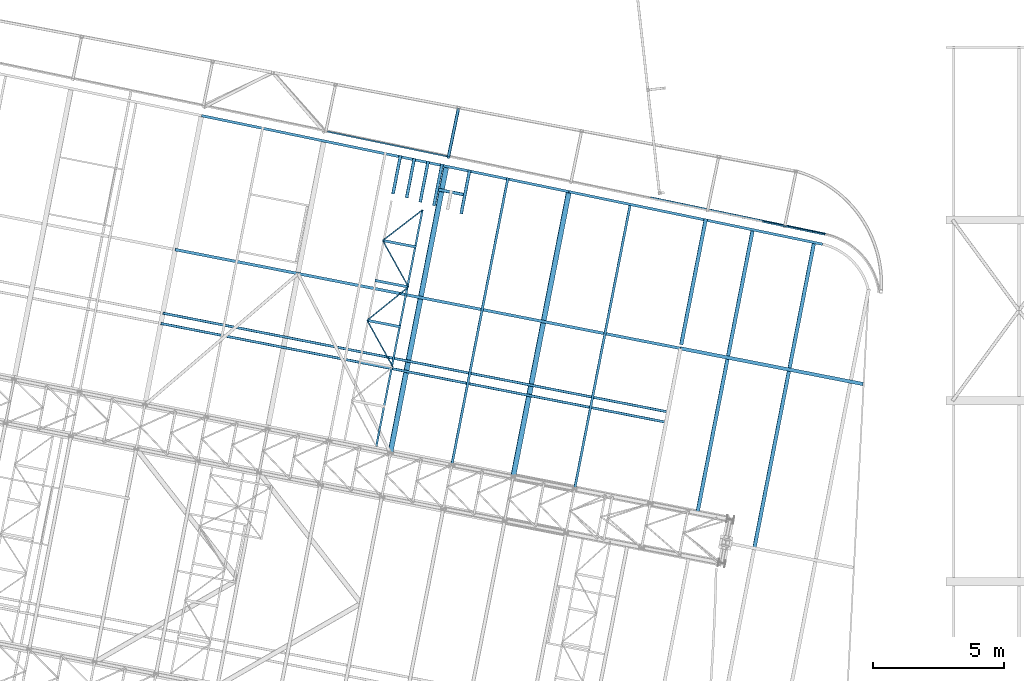
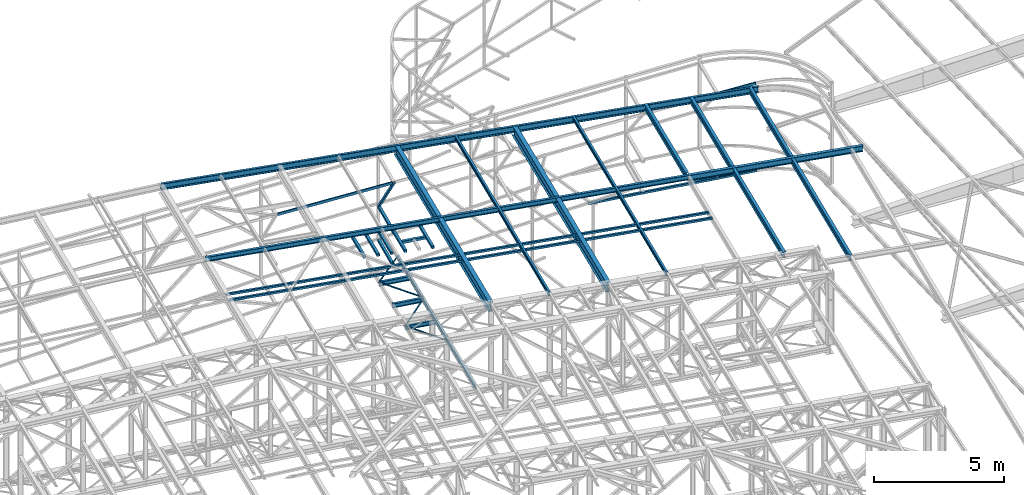
# One storey, part 99 of 215: 32 beams, 1 member, 33 elements without a shape of their own.
"""IFC2X3 building model written with IfcOpenShell, lengths in millimetres."""

from ifc_helpers import new_model, si_unit, frame, origin_with_axes, origin_2d_with_axis, place, context, subcontext, project, spatial, hollow_rectangle, i_section, u_section, extrude, clip, halfspace, material, type_object, element, aggregate, save


model = new_model("IFC2X3")

# Units and contexts
model_context = context("Model", 3, precision=1e-05, world=origin_with_axes())
body_context = subcontext(model_context, "Body", "Model", "MODEL_VIEW")
ifc_project = project(units=[si_unit("LENGTHUNIT", "METRE", prefix="MILLI"), si_unit("AREAUNIT", "SQUARE_METRE"), si_unit("VOLUMEUNIT", "CUBIC_METRE"), si_unit("MASSUNIT", "GRAM", prefix="KILO"), si_unit("TIMEUNIT", "SECOND"), si_unit("PLANEANGLEUNIT", "RADIAN"), si_unit("SOLIDANGLEUNIT", "STERADIAN"), si_unit("THERMODYNAMICTEMPERATUREUNIT", "DEGREE_CELSIUS"), si_unit("LUMINOUSINTENSITYUNIT", "LUMEN")], contexts=[model_context])

# Site, building, storey
site_placement = place(None, origin_with_axes())
site = spatial("IfcSite", under=ifc_project, at=site_placement, CompositionType="ELEMENT")
building_placement = place(site_placement, origin_with_axes())
building = spatial("IfcBuilding", under=site, at=building_placement, Name="Undefined", CompositionType="ELEMENT")
storey_placement = place(building_placement, origin_with_axes())
storey = spatial("IfcBuildingStorey", under=building, at=storey_placement, Name="Undefined", CompositionType="ELEMENT", Elevation=0.0)

# Assembly, beam
assembly_1_placement = place(storey_placement, origin_with_axes())
assembly_1 = element("IfcElementAssembly", 1, at=assembly_1_placement, inside=storey, Name="Steel Assembly", AssemblyPlace="NOTDEFINED", PredefinedType="RIGID_FRAME")
ifc_material = material(Name="STEEL/S275JR")
beam_type_1 = type_object("IfcBeamType", Name="IPE270", PredefinedType="NOTDEFINED")
beam_1_placement = place(assembly_1_placement, frame((100707.23121644, 49411.6988789502, 11955.4438680864), z_axis=(0.0304080349965938, -0.00594450399933318, 0.999519891888024), x_axis=(-0.980951221876683, 0.191767344975893, 0.0309836359961049)))
beam_1 = element("IfcBeam", 2, at=beam_1_placement, type_object=beam_type_1, material=ifc_material, Name="TRAVERSE", ObjectType="IPE270", context=body_context, shape_type="SweptSolid", body=[
    extrude(i_section(OverallWidth=135.0, OverallDepth=270.0, WebThickness=6.599999905, FlangeThickness=10.19999981, FilletRadius=15.0, at=origin_2d_with_axis()), frame((7103.1034453128, -3.20526009538818e-13, 0.0), z_axis=(-1.0, 0.0, 0.0), x_axis=(-6.93889390390723e-18, -1.0, -3.46944695195361e-18)), (0.0, 0.0, 1.0), 7103.1),
])
aggregate(assembly_1, [beam_1])

assembly_2_placement = place(storey_placement, origin_with_axes())
assembly_2 = element("IfcElementAssembly", 3, at=assembly_2_placement, inside=storey, Name="Steel Assembly", AssemblyPlace="NOTDEFINED", PredefinedType="RIGID_FRAME")
beam_2_placement = place(assembly_2_placement, frame((94696.1400825468, 55667.7027853643, 12176.4184972957), z_axis=(-0.0304080339975108, 0.00594450399951394, -0.999519891918418), x_axis=(-0.191859508000518, -0.981422401002646, -1.00000033853845e-09)))
beam_2 = element("IfcBeam", 4, at=beam_2_placement, type_object=beam_type_1, material=ifc_material, ObjectType="IPE270", context=body_context, shape_type="Clipping", body=[
    clip(extrude(i_section(OverallWidth=135.0, OverallDepth=270.0, WebThickness=6.599999905, FlangeThickness=10.19999981, FilletRadius=15.0, at=origin_2d_with_axis()), frame((4844.78748457734, -1.445755833281e-11, 1.82295988638934e-12), z_axis=(-1.0, 0.0, 0.0), x_axis=(-6.93889390390723e-18, -1.0, -3.46944695195361e-18)), (0.0, 0.0, 1.0), 4957.0), halfspace(frame((-57.8522149335477, -299.270143802947, 12172.9903718911), z_axis=(0.999938312877608, 0.0111018920303277, 0.000344140712308602), x_axis=(-1.55650195665657e-09, 0.0309836416144971, -0.999519891724174)), True)),
])
aggregate(assembly_2, [beam_2])

assembly_3_placement = place(storey_placement, origin_with_axes())
assembly_3 = element("IfcElementAssembly", 5, at=assembly_3_placement, inside=storey, Name="Steel Assembly", AssemblyPlace="NOTDEFINED", PredefinedType="RIGID_FRAME")
beam_3_placement = place(assembly_3_placement, frame((96557.6967211372, 43142.8449934824, 12044.4005914881), z_axis=(0.0304080349965938, -0.00594450399933318, 0.999519891888024), x_axis=(0.191863232960539, 0.981421672798148, -1.19000000001358e-07)))
beam_3 = element("IfcBeam", 6, at=beam_3_placement, type_object=beam_type_1, material=ifc_material, ObjectType="IPE270", context=body_context, shape_type="Clipping", body=[
    clip(extrude(i_section(OverallWidth=135.0, OverallDepth=270.0, WebThickness=6.599999905, FlangeThickness=10.19999981, FilletRadius=15.0, at=origin_2d_with_axis()), frame((12000.275121303, 3.47876669497256e-13, -8.68726319428626e-15), z_axis=(-1.0, 0.0, 0.0), x_axis=(-6.93889390390723e-18, -1.0, -3.46944695195361e-18)), (0.0, 0.0, 1.0), 12000.3), halfspace(frame((11948.0422010273, -101.391752407799, -12047.0416624996), z_axis=(0.999938514081791, -0.0110837688422926, 0.000343691942567653), x_axis=(-1.11477173049934e-07, 0.0309836363285431, 0.999519891888024)), False)),
])
aggregate(assembly_3, [beam_3])

assembly_4_placement = place(storey_placement, origin_with_axes())
assembly_4 = element("IfcElementAssembly", 7, at=assembly_4_placement, inside=storey, Name="Steel Assembly", AssemblyPlace="NOTDEFINED", PredefinedType="RIGID_FRAME")
beam_4_placement = place(assembly_4_placement, frame((94384.2962147802, 44489.533243236, 12118.5356235936), z_axis=(0.0304080349965938, -0.00594450399933318, 0.999519891888024), x_axis=(0.191845211931802, 0.981425195651121, 9.9999994476379e-10)))
beam_4 = element("IfcBeam", 8, at=beam_4_placement, type_object=beam_type_1, material=ifc_material, ObjectType="IPE270", context=body_context, shape_type="Clipping", body=[
    clip(extrude(i_section(OverallWidth=135.0, OverallDepth=270.0, WebThickness=6.599999905, FlangeThickness=10.19999981, FilletRadius=15.0, at=origin_2d_with_axis()), frame((11122.1477016745, -1.45519152283669e-11, 0.0), z_axis=(-1.0, 0.0, 0.0), x_axis=(-6.93889390390723e-18, -1.0, -3.46944695195361e-18)), (0.0, 0.0, 1.0), 11122.1), halfspace(frame((11069.8103499635, -114.010455299445, -12120.8224702647), z_axis=(-0.999938146591681, 0.0111168447564954, -0.000344606230971227), x_axis=(-1.11477173049934e-07, 0.0309836363285431, 0.999519891888024)), True)),
])
aggregate(assembly_4, [beam_4])

assembly_5_placement = place(storey_placement, origin_with_axes())
assembly_5 = element("IfcElementAssembly", 9, at=assembly_5_placement, inside=storey, Name="Steel Assembly", AssemblyPlace="NOTDEFINED", PredefinedType="RIGID_FRAME")
beam_type_2 = type_object("IfcBeamType", PredefinedType="NOTDEFINED")
beam_5_placement = place(assembly_5_placement, frame((84507.3845656861, 56831.7887650236, 8709.9999999772), z_axis=(0.0, 0.0, -1.0), x_axis=(0.981422136483614, -0.191860861094538, 0.0)))
beam_5 = element("IfcBeam", 10, at=beam_5_placement, type_object=beam_type_2, material=ifc_material, context=body_context, shape_type="SweptSolid", body=[
    extrude(hollow_rectangle(XDim=120.0, YDim=120.0, WallThickness=5.0, InnerFilletRadius=5.0, OuterFilletRadius=10.0, at=origin_2d_with_axis()), frame((960.000000021923, -2.66453525916122e-14, 0.0), z_axis=(-1.0, 0.0, 0.0), x_axis=(-6.93889390390723e-18, -1.0, -3.46944695195361e-18)), (0.0, 0.0, 1.0), 960.0),
])
aggregate(assembly_5, [beam_5])

assembly_6_placement = place(storey_placement, origin_with_axes())
assembly_6 = element("IfcElementAssembly", 11, at=assembly_6_placement, inside=storey, Name="Steel Assembly", AssemblyPlace="NOTDEFINED", PredefinedType="RIGID_FRAME")
beam_6_placement = place(assembly_6_placement, frame((84326.0255883103, 56216.8133377189, 8710.00000001529), z_axis=(0.0, 0.0, -1.0), x_axis=(0.191860861094545, 0.981422136483613, 0.0)))
beam_6 = element("IfcBeam", 12, at=beam_6_placement, type_object=beam_type_2, material=ifc_material, context=body_context, shape_type="SweptSolid", body=[
    extrude(hollow_rectangle(XDim=120.0, YDim=120.0, WallThickness=5.0, InnerFilletRadius=5.0, OuterFilletRadius=10.0, at=origin_2d_with_axis()), frame((1625.85446433249, 0.0, 0.0), z_axis=(-1.0, 0.0, 0.0), x_axis=(-6.93889390390723e-18, -1.0, -3.46944695195361e-18)), (0.0, 0.0, 1.0), 1625.9),
])
aggregate(assembly_6, [beam_6])

assembly_7_placement = place(storey_placement, origin_with_axes())
assembly_7 = element("IfcElementAssembly", 13, at=assembly_7_placement, inside=storey, Name="Steel Assembly", AssemblyPlace="NOTDEFINED", PredefinedType="RIGID_FRAME")
beam_7_placement = place(assembly_7_placement, frame((83802.4829464873, 56353.2854755301, 8710.00000001752), z_axis=(0.0, 0.0, -1.0), x_axis=(0.191860861094545, 0.981422136483613, 0.0)))
beam_7 = element("IfcBeam", 14, at=beam_7_placement, type_object=beam_type_2, material=ifc_material, context=body_context, shape_type="SweptSolid", body=[
    extrude(hollow_rectangle(XDim=120.0, YDim=120.0, WallThickness=5.0, InnerFilletRadius=5.0, OuterFilletRadius=10.0, at=origin_2d_with_axis()), frame((1592.36502932667, -4.41970079791596e-14, 0.0), z_axis=(-1.0, 0.0, 0.0), x_axis=(-6.93889390390723e-18, -1.0, -3.46944695195361e-18)), (0.0, 0.0, 1.0), 1592.4),
])
aggregate(assembly_7, [beam_7])

assembly_8_placement = place(storey_placement, origin_with_axes())
assembly_8 = element("IfcElementAssembly", 15, at=assembly_8_placement, inside=storey, Name="Steel Assembly", AssemblyPlace="NOTDEFINED", PredefinedType="RIGID_FRAME")
beam_8_placement = place(assembly_8_placement, frame((83284.5034089616, 56518.2144525456, 8710.00000001459), z_axis=(0.0, 0.0, -1.0), x_axis=(0.191860861094545, 0.981422136483613, 0.0)))
beam_8 = element("IfcBeam", 16, at=beam_8_placement, type_object=beam_type_2, material=ifc_material, context=body_context, shape_type="SweptSolid", body=[
    extrude(hollow_rectangle(XDim=120.0, YDim=120.0, WallThickness=5.0, InnerFilletRadius=5.0, OuterFilletRadius=10.0, at=origin_2d_with_axis()), frame((1529.88008044036, 0.0, -1.81898940354586e-12), z_axis=(-1.0, 0.0, 0.0), x_axis=(-6.93889390390723e-18, -1.0, -3.46944695195361e-18)), (0.0, 0.0, 1.0), 1529.9),
])
aggregate(assembly_8, [beam_8])

assembly_9_placement = place(storey_placement, origin_with_axes())
assembly_9 = element("IfcElementAssembly", 17, at=assembly_9_placement, inside=storey, Name="Steel Assembly", AssemblyPlace="NOTDEFINED", PredefinedType="RIGID_FRAME")
beam_9_placement = place(assembly_9_placement, frame((85366.045242537, 55907.7263847116, 8710.00000000988), z_axis=(0.0, 0.0, -1.0), x_axis=(0.191860861094545, 0.981422136483613, 0.0)))
beam_9 = element("IfcBeam", 18, at=beam_9_placement, type_object=beam_type_2, material=ifc_material, context=body_context, shape_type="SweptSolid", body=[
    extrude(hollow_rectangle(XDim=120.0, YDim=120.0, WallThickness=5.0, InnerFilletRadius=5.0, OuterFilletRadius=10.0, at=origin_2d_with_axis()), frame((1712.99697636655, 4.75452171068856e-14, 0.0), z_axis=(-1.0, 0.0, 0.0), x_axis=(-6.93889390390723e-18, -1.0, -3.46944695195361e-18)), (0.0, 0.0, 1.0), 1713.0),
])
aggregate(assembly_9, [beam_9])

assembly_10_placement = place(storey_placement, origin_with_axes())
assembly_10 = element("IfcElementAssembly", 19, at=assembly_10_placement, inside=storey, Name="Steel Assembly", AssemblyPlace="NOTDEFINED", PredefinedType="RIGID_FRAME")
beam_10_placement = place(assembly_10_placement, frame((82763.4577222921, 56667.4592165135, 8710.00000000836), z_axis=(0.0, 0.0, -1.0), x_axis=(0.191860861094545, 0.981422136483613, 0.0)))
beam_10 = element("IfcBeam", 20, at=beam_10_placement, type_object=beam_type_2, material=ifc_material, context=body_context, shape_type="SweptSolid", body=[
    extrude(hollow_rectangle(XDim=120.0, YDim=120.0, WallThickness=5.0, InnerFilletRadius=5.0, OuterFilletRadius=10.0, at=origin_2d_with_axis()), frame((1497.35905620603, 0.0, 0.0), z_axis=(-1.0, 0.0, 0.0), x_axis=(-6.93889390390723e-18, -1.0, -3.46944695195361e-18)), (0.0, 0.0, 1.0), 1497.4),
])
aggregate(assembly_10, [beam_10])

assembly_11_placement = place(storey_placement, origin_with_axes())
assembly_11 = element("IfcElementAssembly", 21, at=assembly_11_placement, inside=storey, Name="Steel Assembly", AssemblyPlace="NOTDEFINED", PredefinedType="RIGID_FRAME")
beam_11_placement = place(assembly_11_placement, frame((85256.4215637846, 59899.7622415471, 6680.22396478486), z_axis=(0.979315017537065, -0.202341534110965, 0.0), x_axis=(-0.202341520089688, -0.979315020434076, -1.000000338979e-09)))
beam_11 = element("IfcBeam", 22, at=beam_11_placement, type_object=beam_type_2, material=ifc_material, context=body_context, shape_type="SweptSolid", body=[
    extrude(hollow_rectangle(XDim=120.0, YDim=120.0, WallThickness=5.0, InnerFilletRadius=5.0, OuterFilletRadius=10.0, at=origin_2d_with_axis()), frame((1873.33697915903, 0.0, -5.19955461786024e-14), z_axis=(-1.0, 0.0, 0.0), x_axis=(-6.93889390390723e-18, -1.0, -3.46944695195361e-18)), (0.0, 0.0, 1.0), 1873.3),
])
aggregate(assembly_11, [beam_11])

assembly_12_placement = place(storey_placement, origin_with_axes())
assembly_12 = element("IfcElementAssembly", 23, at=assembly_12_placement, inside=storey, Name="Steel Assembly", AssemblyPlace="NOTDEFINED", PredefinedType="RIGID_FRAME")
beam_12_placement = place(assembly_12_placement, frame((85256.4215637935, 59899.7622415429, 8267.55297995395), z_axis=(0.979315017537065, -0.202341534110965, 0.0), x_axis=(-0.202341520089688, -0.979315020434076, -1.000000338979e-09)))
beam_12 = element("IfcBeam", 24, at=beam_12_placement, type_object=beam_type_2, material=ifc_material, context=body_context, shape_type="SweptSolid", body=[
    extrude(hollow_rectangle(XDim=120.0, YDim=120.0, WallThickness=5.0, InnerFilletRadius=5.0, OuterFilletRadius=10.0, at=origin_2d_with_axis()), frame((1873.33697915903, 0.0, -5.19955461786024e-14), z_axis=(-1.0, 0.0, 0.0), x_axis=(-6.93889390390723e-18, -1.0, -3.46944695195361e-18)), (0.0, 0.0, 1.0), 1873.3),
])
aggregate(assembly_12, [beam_12])

assembly_13_placement = place(storey_placement, origin_with_axes())
assembly_13 = element("IfcElementAssembly", 25, at=assembly_13_placement, inside=storey, Name="Steel Assembly", AssemblyPlace="NOTDEFINED", PredefinedType="RIGID_FRAME")
beam_type_3 = type_object("IfcBeamType", PredefinedType="NOTDEFINED")
beam_13_placement = place(assembly_13_placement, frame((92596.8966885461, 56519.4992647334, 7879.61551005311), z_axis=(0.203415415993803, 0.979092522970154, -7.99999997955808e-08), x_axis=(0.979060179671381, -0.203408695931727, 0.00812816099727176)))
beam_13 = element("IfcBeam", 26, at=beam_13_placement, type_object=beam_type_3, material=ifc_material, Name="LISSE", context=body_context, shape_type="SweptSolid", body=[
    extrude(hollow_rectangle(XDim=100.0, YDim=100.0, WallThickness=5.0, InnerFilletRadius=5.0, OuterFilletRadius=10.0, at=origin_2d_with_axis()), frame((6834.47893677168, 0.0, -1.42196319762222e-11), z_axis=(-1.0, 0.0, 0.0), x_axis=(-6.93889390390723e-18, -1.0, -3.46944695195361e-18)), (0.0, 0.0, 1.0), 6834.5),
])
aggregate(assembly_13, [beam_13])

assembly_14_placement = place(storey_placement, origin_with_axes())
assembly_14 = element("IfcElementAssembly", 27, at=assembly_14_placement, inside=storey, Name="Steel Assembly", AssemblyPlace="NOTDEFINED", PredefinedType="RIGID_FRAME")
beam_14_placement = place(assembly_14_placement, frame((73979.038016216, 52117.5203848683, 12789.6972982422), z_axis=(-0.0304080339975108, 0.00594450399951394, -0.999519891918418), x_axis=(0.980943076639626, -0.191809005929534, -0.0309836349886174)))
beam_14 = element("IfcBeam", 28, at=beam_14_placement, type_object=beam_type_3, material=ifc_material, context=body_context, shape_type="SweptSolid", body=[
    extrude(hollow_rectangle(XDim=100.0, YDim=100.0, WallThickness=5.0, InnerFilletRadius=5.0, OuterFilletRadius=10.0, at=origin_2d_with_axis()), frame((19666.2260350888, 7.85512124139754e-13, 1.81898940354586e-12), z_axis=(-1.0, 0.0, 0.0), x_axis=(-6.93889390390723e-18, -1.0, -3.46944695195361e-18)), (0.0, 0.0, 1.0), 19666.2),
])
aggregate(assembly_14, [beam_14])

assembly_15_placement = place(storey_placement, origin_with_axes())
assembly_15 = element("IfcElementAssembly", 29, at=assembly_15_placement, inside=storey, Name="Steel Assembly", AssemblyPlace="NOTDEFINED", PredefinedType="RIGID_FRAME")
beam_15_placement = place(assembly_15_placement, frame((73901.7838214901, 51725.051223685, 12789.6972993589), z_axis=(-0.0304080339975108, 0.00594450399951394, -0.999519891918418), x_axis=(0.980943076639626, -0.191809005929534, -0.0309836349886174)))
beam_15 = element("IfcBeam", 30, at=beam_15_placement, type_object=beam_type_3, material=ifc_material, context=body_context, shape_type="SweptSolid", body=[
    extrude(hollow_rectangle(XDim=100.0, YDim=100.0, WallThickness=5.0, InnerFilletRadius=5.0, OuterFilletRadius=10.0, at=origin_2d_with_axis()), frame((19666.7288325615, 1.47390537647347e-11, -6.82326724030288e-14), z_axis=(-1.0, 0.0, 0.0), x_axis=(-6.93889390390723e-18, -1.0, -3.46944695195361e-18)), (0.0, 0.0, 1.0), 19666.7),
])
aggregate(assembly_15, [beam_15])

assembly_16_placement = place(storey_placement, origin_with_axes())
assembly_16 = element("IfcElementAssembly", 31, at=assembly_16_placement, inside=storey, Name="Steel Assembly", AssemblyPlace="NOTDEFINED", PredefinedType="RIGID_FRAME")
beam_type_4 = type_object("IfcBeamType", PredefinedType="NOTDEFINED")
beam_16_placement = place(assembly_16_placement, frame((81777.8800450432, 51843.5573353207, 8745.0), z_axis=(0.0, 0.0, -1.0), x_axis=(0.483553584905505, -0.875314760828946, 0.0)))
beam_16 = element("IfcBeam", 32, at=beam_16_placement, type_object=beam_type_4, material=ifc_material, context=body_context, shape_type="SweptSolid", body=[
    extrude(hollow_rectangle(XDim=50.0, YDim=50.0, WallThickness=3.0, InnerFilletRadius=3.0, OuterFilletRadius=6.0, at=origin_2d_with_axis()), frame((2026.56728111941, 0.0, 0.0), z_axis=(-1.0, 0.0, 0.0), x_axis=(-6.93889390390723e-18, -1.0, -3.46944695195361e-18)), (0.0, 0.0, 1.0), 2026.6),
])
aggregate(assembly_16, [beam_16])

assembly_17_placement = place(storey_placement, origin_with_axes())
assembly_17 = element("IfcElementAssembly", 33, at=assembly_17_placement, inside=storey, Name="Steel Assembly", AssemblyPlace="NOTDEFINED", PredefinedType="RIGID_FRAME")
beam_17_placement = place(assembly_17_placement, frame((83353.7207232952, 53117.8024188517, 8745.0), z_axis=(0.0, 0.0, -1.0), x_axis=(-0.777591169660664, -0.628770206725606, 0.0)))
beam_17 = element("IfcBeam", 34, at=beam_17_placement, type_object=beam_type_4, material=ifc_material, context=body_context, shape_type="SweptSolid", body=[
    extrude(hollow_rectangle(XDim=50.0, YDim=50.0, WallThickness=3.0, InnerFilletRadius=3.0, OuterFilletRadius=6.0, at=origin_2d_with_axis()), frame((2026.56718786147, 2.24994155291366e-13, 0.0), z_axis=(-1.0, 0.0, 0.0), x_axis=(-6.93889390390723e-18, -1.0, -3.46944695195361e-18)), (0.0, 0.0, 1.0), 2026.6),
])
aggregate(assembly_17, [beam_17])

assembly_18_placement = place(storey_placement, origin_with_axes())
assembly_18 = element("IfcElementAssembly", 35, at=assembly_18_placement, inside=storey, Name="Steel Assembly", AssemblyPlace="NOTDEFINED", PredefinedType="RIGID_FRAME")
beam_18_placement = place(assembly_18_placement, frame((82373.7669208555, 54891.6866599469, 8745.0), z_axis=(0.0, 0.0, -1.0), x_axis=(0.483553584905505, -0.875314760828946, 0.0)))
beam_18 = element("IfcBeam", 36, at=beam_18_placement, type_object=beam_type_4, material=ifc_material, context=body_context, shape_type="SweptSolid", body=[
    extrude(hollow_rectangle(XDim=50.0, YDim=50.0, WallThickness=3.0, InnerFilletRadius=3.0, OuterFilletRadius=6.0, at=origin_2d_with_axis()), frame((2026.56718786147, 2.24994155291366e-13, 0.0), z_axis=(-1.0, 0.0, 0.0), x_axis=(-6.93889390390723e-18, -1.0, -3.46944695195361e-18)), (0.0, 0.0, 1.0), 2026.6),
])
aggregate(assembly_18, [beam_18])

assembly_19_placement = place(storey_placement, origin_with_axes())
assembly_19 = element("IfcElementAssembly", 37, at=assembly_19_placement, inside=storey, Name="Steel Assembly", AssemblyPlace="NOTDEFINED", PredefinedType="RIGID_FRAME")
beam_19_placement = place(assembly_19_placement, frame((83890.4643411294, 56058.8507650693, 8744.99999998962), z_axis=(0.0, 0.0, -1.0), x_axis=(-0.792504335295169, -0.609866279227146, 0.0)))
beam_19 = element("IfcBeam", 38, at=beam_19_placement, type_object=beam_type_4, material=ifc_material, context=body_context, shape_type="SweptSolid", body=[
    extrude(hollow_rectangle(XDim=50.0, YDim=50.0, WallThickness=3.0, InnerFilletRadius=3.0, OuterFilletRadius=6.0, at=origin_2d_with_axis()), frame((1913.80331128976, 0.0, 1.81898940354586e-12), z_axis=(-1.0, 0.0, 0.0), x_axis=(-6.93889390390723e-18, -1.0, -3.46944695195361e-18)), (0.0, 0.0, 1.0), 1913.8),
])
aggregate(assembly_19, [beam_19])

assembly_20_placement = place(storey_placement, origin_with_axes())
assembly_20 = element("IfcElementAssembly", 39, at=assembly_20_placement, inside=storey, Name="Steel Assembly", AssemblyPlace="NOTDEFINED", PredefinedType="RIGID_FRAME")
beam_type_5 = type_object("IfcBeamType", Name="IPE180", PredefinedType="NOTDEFINED")
beam_20_placement = place(assembly_20_placement, frame((89697.5688418954, 45405.7473703223, 12311.5889128037), z_axis=(0.0304080349965938, -0.00594450399933318, 0.999519891888024), x_axis=(0.191845211931802, 0.981425195651121, 9.9999994476379e-10)))
beam_20 = element("IfcBeam", 40, at=beam_20_placement, type_object=beam_type_5, material=ifc_material, ObjectType="IPE180", context=body_context, shape_type="Clipping", body=[
    clip(extrude(i_section(OverallWidth=91.0, OverallDepth=180.0, WebThickness=5.300000191, FlangeThickness=8.0, FilletRadius=9.0, at=origin_2d_with_axis()), frame((11157.1587552887, -1.45519152283669e-11, 9.67729260899973e-15), z_axis=(-1.0, 0.0, 0.0), x_axis=(-6.93889390390723e-18, -1.0, -3.46944695195361e-18)), (0.0, 0.0, 1.0), 11157.2), halfspace(frame((11120.8339455716, -301.644985928389, -12308.1520979139), z_axis=(-0.999936956705406, 0.0112232605275007, -0.000347904962252072), x_axis=(-1.11477173049934e-07, 0.0309836363285431, 0.999519891888024)), True)),
])
aggregate(assembly_20, [beam_20])

assembly_21_placement = place(storey_placement, origin_with_axes())
assembly_21 = element("IfcElementAssembly", 41, at=assembly_21_placement, inside=storey, Name="Steel Assembly", AssemblyPlace="NOTDEFINED", PredefinedType="RIGID_FRAME")
beam_21_placement = place(assembly_21_placement, frame((85009.4731007826, 46322.2289804221, 12459.663807014), z_axis=(0.0304080349965938, -0.00594450399933318, 0.999519891888024), x_axis=(0.191845211931802, 0.981425195651121, 9.9999994476379e-10)))
beam_21 = element("IfcBeam", 42, at=beam_21_placement, type_object=beam_type_5, material=ifc_material, ObjectType="IPE180", context=body_context, shape_type="Clipping", body=[
    clip(extrude(i_section(OverallWidth=91.0, OverallDepth=180.0, WebThickness=5.300000191, FlangeThickness=8.0, FilletRadius=9.0, at=origin_2d_with_axis()), frame((11210.2292296254, 1.48630615934183e-11, 1.81898940354586e-12), z_axis=(-1.0, 0.0, 0.0), x_axis=(-6.93889390390723e-18, -1.0, -3.46944695195361e-18)), (0.0, 0.0, 1.0), 11210.2), halfspace(frame((11174.1081668215, -284.142120759541, -12456.8406810643), z_axis=(0.999945433348255, -0.0104415306395667, 0.000323672477693397), x_axis=(-1.11477173049934e-07, 0.0309836363285431, 0.999519891888024)), False)),
])
aggregate(assembly_21, [beam_21])

assembly_22_placement = place(storey_placement, origin_with_axes())
assembly_22 = element("IfcElementAssembly", 43, at=assembly_22_placement, inside=storey, Name="Steel Assembly", AssemblyPlace="NOTDEFINED", PredefinedType="RIGID_FRAME")
beam_type_6 = type_object("IfcBeamType", Name="UPN200", PredefinedType="NOTDEFINED")
beam_22_placement = place(assembly_22_placement, frame((82125.1437133901, 47028.7404434372, 8670.00000000005), z_axis=(0.0, 0.0, -1.0), x_axis=(0.191860861094545, 0.981422136483613, 0.0)))
beam_22 = element("IfcBeam", 44, at=beam_22_placement, type_object=beam_type_6, material=ifc_material, ObjectType="UPN200", context=body_context, shape_type="SweptSolid", body=[
    extrude(u_section(Depth=200.0, FlangeWidth=75.0, WebThickness=8.5, FlangeThickness=11.5, FilletRadius=11.5, EdgeRadius=6.0, FlangeSlope=0.0798299857122373, at=origin_2d_with_axis()), frame((9201.04610041369, 0.0, -1.81898940354586e-12), z_axis=(-1.0, 0.0, 0.0), x_axis=(-6.93889390390723e-18, -1.0, -3.46944695195361e-18)), (0.0, 0.0, 1.0), 9201.0),
])
aggregate(assembly_22, [beam_22])

# Assembly, member
assembly_23_placement = place(storey_placement, origin_with_axes())
assembly_23 = element("IfcElementAssembly", 45, at=assembly_23_placement, inside=storey, Name="Steel Assembly", AssemblyPlace="NOTDEFINED", PredefinedType="RIGID_FRAME")
member_type = type_object("IfcMemberType", PredefinedType="NOTDEFINED")
member_placement = place(assembly_23_placement, frame((84877.3676866104, 58065.1752056051, 10626.8513099584), z_axis=(-0.979315017578007, 0.20234153391281, 0.0), x_axis=(0.125823382008211, 0.608973973039735, -0.783146970051098)))
member = element("IfcMember", 46, at=member_placement, type_object=member_type, material=ifc_material, context=body_context, shape_type="SweptSolid", body=[
    extrude(hollow_rectangle(XDim=100.0, YDim=100.0, WallThickness=5.0, InnerFilletRadius=5.0, OuterFilletRadius=10.0, at=origin_2d_with_axis()), frame((3012.58693515019, 7.44318978313786e-12, 1.4548225356443e-11), z_axis=(-1.0, 0.0, 0.0), x_axis=(-6.93889390390723e-18, -1.0, -3.46944695195361e-18)), (0.0, 0.0, 1.0), 3012.6),
])
aggregate(assembly_23, [member])

# Assembly, beam
assembly_24_placement = place(storey_placement, origin_with_axes())
assembly_24 = element("IfcElementAssembly", 47, at=assembly_24_placement, inside=storey, Name="Steel Assembly", AssemblyPlace="NOTDEFINED", PredefinedType="RIGID_FRAME")
beam_type_7 = type_object("IfcBeamType", Name="UPN120", PredefinedType="NOTDEFINED")
beam_23_placement = place(assembly_24_placement, frame((96878.2276531763, 55608.5161806536, 11808.7422381779), z_axis=(0.095501801982912, -0.0197734269964623, -0.995232845821937), x_axis=(0.974564275254298, -0.20177435605265, 0.097527343025448)))
beam_23 = element("IfcBeam", 48, at=beam_23_placement, type_object=beam_type_7, material=ifc_material, ObjectType="UPN120", context=body_context, shape_type="SweptSolid", body=[
    extrude(u_section(Depth=120.0, FlangeWidth=55.0, WebThickness=7.0, FlangeThickness=9.0, FilletRadius=9.0, EdgeRadius=4.5, FlangeSlope=0.0798299857122373, at=origin_2d_with_axis()), frame((2429.47926541851, -6.96198284657812e-14, 1.78527360581689e-12), z_axis=(-1.0, 0.0, 0.0), x_axis=(-6.93889390390723e-18, -1.0, -3.46944695195361e-18)), (0.0, 0.0, 1.0), 2429.5),
])
aggregate(assembly_24, [beam_23])

assembly_25_placement = place(storey_placement, origin_with_axes())
assembly_25 = element("IfcElementAssembly", 49, at=assembly_25_placement, inside=storey, Name="Steel Assembly", AssemblyPlace="NOTDEFINED", PredefinedType="RIGID_FRAME")
beam_24_placement = place(assembly_25_placement, frame((80263.9469327851, 59048.5584119375, 10148.642025646), z_axis=(0.0955013479802835, -0.0197756209959169, -0.995232845794478), x_axis=(0.974558265687658, -0.201803379935323, 0.0975273429687428)))
beam_24 = element("IfcBeam", 50, at=beam_24_placement, type_object=beam_type_7, material=ifc_material, ObjectType="UPN120", context=body_context, shape_type="SweptSolid", body=[
    extrude(u_section(Depth=120.0, FlangeWidth=55.0, WebThickness=7.0, FlangeThickness=9.0, FilletRadius=9.0, EdgeRadius=4.5, FlangeSlope=0.0798299857122373, at=origin_2d_with_axis()), frame((4672.97368184988, 2.89023229869486e-11, -3.8989681369825e-13), z_axis=(-1.0, 0.0, 0.0), x_axis=(-6.93889390390723e-18, -1.0, -3.46944695195361e-18)), (0.0, 0.0, 1.0), 4673.0),
])
aggregate(assembly_25, [beam_24])

assembly_26_placement = place(storey_placement, origin_with_axes())
assembly_26 = element("IfcElementAssembly", 51, at=assembly_26_placement, inside=storey, Name="Steel Assembly", AssemblyPlace="NOTDEFINED", PredefinedType="RIGID_FRAME")
beam_type_8 = type_object("IfcBeamType", Name="IPE200", PredefinedType="NOTDEFINED")
beam_25_placement = place(assembly_26_placement, frame((83651.664232917, 54641.8670669838, 8670.00000000005), z_axis=(0.0, 0.0, -1.0), x_axis=(-0.981422136295317, 0.191860862057732, 0.0)))
beam_25 = element("IfcBeam", 52, at=beam_25_placement, type_object=beam_type_8, material=ifc_material, ObjectType="IPE200", context=body_context, shape_type="SweptSolid", body=[
    extrude(i_section(OverallWidth=100.0, OverallDepth=200.0, WebThickness=5.599999905, FlangeThickness=8.5, FilletRadius=12.0, at=origin_2d_with_axis()), frame((1302.08731245854, -3.61401828590942e-14, 0.0), z_axis=(-1.0, 0.0, 0.0), x_axis=(-6.93889390390723e-18, -1.0, -3.46944695195361e-18)), (0.0, 0.0, 1.0), 1302.1),
])
aggregate(assembly_26, [beam_25])

assembly_27_placement = place(storey_placement, origin_with_axes())
assembly_27 = element("IfcElementAssembly", 53, at=assembly_27_placement, inside=storey, Name="Steel Assembly", AssemblyPlace="NOTDEFINED", PredefinedType="RIGID_FRAME")
beam_26_placement = place(assembly_27_placement, frame((83353.7207232754, 53117.802418746, 8670.00000000005), z_axis=(0.0, 0.0, -1.0), x_axis=(-0.981422136295317, 0.191860862057732, 0.0)))
beam_26 = element("IfcBeam", 54, at=beam_26_placement, type_object=beam_type_8, material=ifc_material, ObjectType="IPE200", context=body_context, shape_type="SweptSolid", body=[
    extrude(i_section(OverallWidth=100.0, OverallDepth=200.0, WebThickness=5.599999905, FlangeThickness=8.5, FilletRadius=12.0, at=origin_2d_with_axis()), frame((1302.0872393519, 0.0, 0.0), z_axis=(-1.0, 0.0, 0.0), x_axis=(-6.93889390390723e-18, -1.0, -3.46944695195361e-18)), (0.0, 0.0, 1.0), 1302.1),
])
aggregate(assembly_27, [beam_26])

assembly_28_placement = place(storey_placement, origin_with_axes())
assembly_28 = element("IfcElementAssembly", 55, at=assembly_28_placement, inside=storey, Name="Steel Assembly", AssemblyPlace="NOTDEFINED", PredefinedType="RIGID_FRAME")
beam_27_placement = place(assembly_28_placement, frame((83055.7773571242, 51593.7377424211, 8670.00000000005), z_axis=(0.0, 0.0, -1.0), x_axis=(-0.981422136295317, 0.191860862057732, 0.0)))
beam_27 = element("IfcBeam", 56, at=beam_27_placement, type_object=beam_type_8, material=ifc_material, ObjectType="IPE200", context=body_context, shape_type="SweptSolid", body=[
    extrude(i_section(OverallWidth=100.0, OverallDepth=200.0, WebThickness=5.599999905, FlangeThickness=8.5, FilletRadius=12.0, at=origin_2d_with_axis()), frame((1302.08731245854, -3.61401828590942e-14, 0.0), z_axis=(-1.0, 0.0, 0.0), x_axis=(-6.93889390390723e-18, -1.0, -3.46944695195361e-18)), (0.0, 0.0, 1.0), 1302.1),
])
aggregate(assembly_28, [beam_27])

assembly_29_placement = place(storey_placement, origin_with_axes())
assembly_29 = element("IfcElementAssembly", 57, at=assembly_29_placement, inside=storey, Name="Steel Assembly", AssemblyPlace="NOTDEFINED", PredefinedType="RIGID_FRAME")
beam_type_9 = type_object("IfcBeamType", Name="IPE220", PredefinedType="NOTDEFINED")
beam_28_placement = place(assembly_29_placement, frame((93740.194262754, 50773.6979274686, 12200.5118379859), z_axis=(0.0304080349965938, -0.00594450399933318, 0.999519891888024), x_axis=(-0.980951221876683, 0.191767344975893, 0.0309836359961049)))
beam_28 = element("IfcBeam", 58, at=beam_28_placement, type_object=beam_type_9, material=ifc_material, Name="POUTRE", ObjectType="IPE220", context=body_context, shape_type="SweptSolid", body=[
    extrude(i_section(OverallWidth=110.0, OverallDepth=220.0, WebThickness=5.900000095, FlangeThickness=9.199999809, FilletRadius=12.0, at=origin_2d_with_axis()), frame((19666.7905282409, 2.75094367016678e-12, 3.77444457999754e-12), z_axis=(-1.0, 0.0, 0.0), x_axis=(-6.93889390390723e-18, -1.0, -3.46944695195361e-18)), (0.0, 0.0, 1.0), 19666.8),
])
aggregate(assembly_29, [beam_28])

assembly_30_placement = place(storey_placement, origin_with_axes())
assembly_30 = element("IfcElementAssembly", 59, at=assembly_30_placement, inside=storey, Name="Steel Assembly", AssemblyPlace="NOTDEFINED", PredefinedType="RIGID_FRAME")
beam_type_10 = type_object("IfcBeamType", Name="UPE300", PredefinedType="NOTDEFINED")
beam_29_placement = place(assembly_30_placement, frame((99158.8548708767, 54750.833363622, 12019.2476039709), z_axis=(-0.0303401319968848, 0.00628188599935255, -0.999519891897456), x_axis=(-0.978760708273087, 0.202651154056542, 0.0309836360086448)))
beam_29 = element("IfcBeam", 60, at=beam_29_placement, type_object=beam_type_10, material=ifc_material, Name="POUTRE", ObjectType="UPE300", context=body_context, shape_type="SweptSolid", body=[
    extrude(u_section(Depth=300.0, FlangeWidth=100.0, WebThickness=9.5, FlangeThickness=15.0, FilletRadius=15.0, at=origin_2d_with_axis()), frame((9890.55420924792, -3.79262464130147e-14, 3.43147531544071e-14), z_axis=(-1.0, 0.0, 0.0), x_axis=(-6.93889390390723e-18, -1.0, -3.46944695195361e-18)), (0.0, 0.0, 1.0), 9890.6),
])
aggregate(assembly_30, [beam_29])

assembly_31_placement = place(storey_placement, origin_with_axes())
assembly_31 = element("IfcElementAssembly", 61, at=assembly_31_placement, inside=storey, Name="Steel Assembly", AssemblyPlace="NOTDEFINED", PredefinedType="RIGID_FRAME")
beam_30_placement = place(assembly_31_placement, frame((89476.2671914119, 56755.6018546855, 12325.6929361024), z_axis=(-0.0303403509965476, 0.00628082999928737, -0.999519891886063), x_axis=(-0.978767758723577, 0.202617098942777, 0.0309836359912497)))
beam_30 = element("IfcBeam", 62, at=beam_30_placement, type_object=beam_type_10, material=ifc_material, Name="POUTRE", ObjectType="UPE300", context=body_context, shape_type="SweptSolid", body=[
    extrude(u_section(Depth=300.0, FlangeWidth=100.0, WebThickness=9.5, FlangeThickness=15.0, FilletRadius=15.0, at=origin_2d_with_axis()), frame((14336.1736572791, -1.13441597923777e-13, -1.76925080954793e-12), z_axis=(-1.0, 0.0, 0.0), x_axis=(-6.93889390390723e-18, -1.0, -3.46944695195361e-18)), (0.0, 0.0, 1.0), 14336.2),
])
aggregate(assembly_31, [beam_30])

assembly_32_placement = place(storey_placement, origin_with_axes())
assembly_32 = element("IfcElementAssembly", 63, at=assembly_32_placement, inside=storey, Name="Steel Assembly", AssemblyPlace="NOTDEFINED", PredefinedType="RIGID_FRAME")
beam_type_11 = type_object("IfcBeamType", Name="IPE450", PredefinedType="NOTDEFINED")
beam_31_placement = place(assembly_32_placement, frame((87349.4269124898, 45864.8314949589, 12248.5986564987), z_axis=(0.0303723669848881, -0.00612697299694933, 0.999519874502568), x_axis=(0.191844764093253, 0.981425265477054, 0.000186476000090693)))
beam_31 = element("IfcBeam", 64, at=beam_31_placement, type_object=beam_type_11, material=ifc_material, ObjectType="IPE450", context=body_context, shape_type="Clipping", body=[
    clip(extrude(i_section(OverallWidth=190.0, OverallDepth=450.0, WebThickness=9.399999619, FlangeThickness=14.60000038, FilletRadius=21.0, at=origin_2d_with_axis()), frame((11225.2084393199, 2.5589207091258e-13, 3.62702545125285e-12), z_axis=(-1.0, 0.0, 0.0), x_axis=(-6.93889390390723e-18, -1.0, -3.46944695195361e-18)), (0.0, 0.0, 1.0), 11225.2), halfspace(frame((11144.1365717851, -384.91532882968, -12244.6296529668), z_axis=(-0.999936777154988, 0.0112434628291881, -0.000161976865897353), x_axis=(0.00018647605278238, 0.0309836360205224, 0.999519874502568)), True)),
])
aggregate(assembly_32, [beam_31])

assembly_33_placement = place(storey_placement, origin_with_axes())
assembly_33 = element("IfcElementAssembly", 65, at=assembly_33_placement, inside=storey, Name="Steel Assembly", AssemblyPlace="NOTDEFINED", PredefinedType="RIGID_FRAME")
beam_32_placement = place(assembly_33_placement, frame((82661.3231072608, 46781.271831827, 12396.6735508702), z_axis=(0.0304080349965938, -0.00594450399933318, 0.999519891888024), x_axis=(0.191845211931802, 0.981425195651121, 9.9999994476379e-10)))
beam_32 = element("IfcBeam", 66, at=beam_32_placement, type_object=beam_type_11, material=ifc_material, Name="POUTRE", ObjectType="IPE450", context=body_context, shape_type="Clipping", body=[
    clip(extrude(i_section(OverallWidth=190.0, OverallDepth=450.0, WebThickness=9.399999619, FlangeThickness=14.60000038, FilletRadius=21.0, at=origin_2d_with_axis()), frame((11278.1346704592, 0.0, 3.63797880709171e-12), z_axis=(-1.0, 0.0, 0.0), x_axis=(-6.93889390390723e-18, -1.0, -3.46944695195361e-18)), (0.0, 0.0, 1.0), 11278.1), halfspace(frame((11201.3657822359, -220.317767023371, -12395.7986296204), z_axis=(0.999938180909594, -0.0111137604733333, 0.000344510309924786), x_axis=(-1.11477173049934e-07, 0.0309836363285431, 0.999519891888024)), False)),
])
aggregate(assembly_33, [beam_32])

save(model, "model.ifc")
